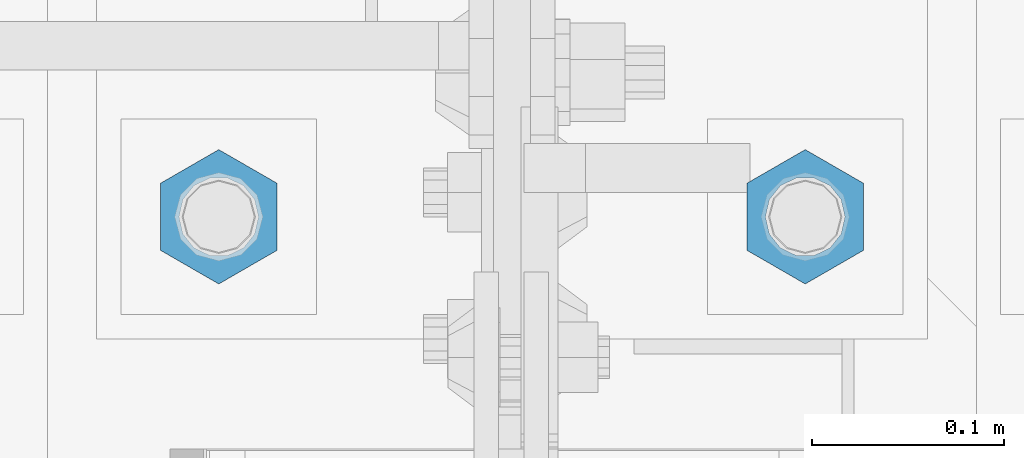
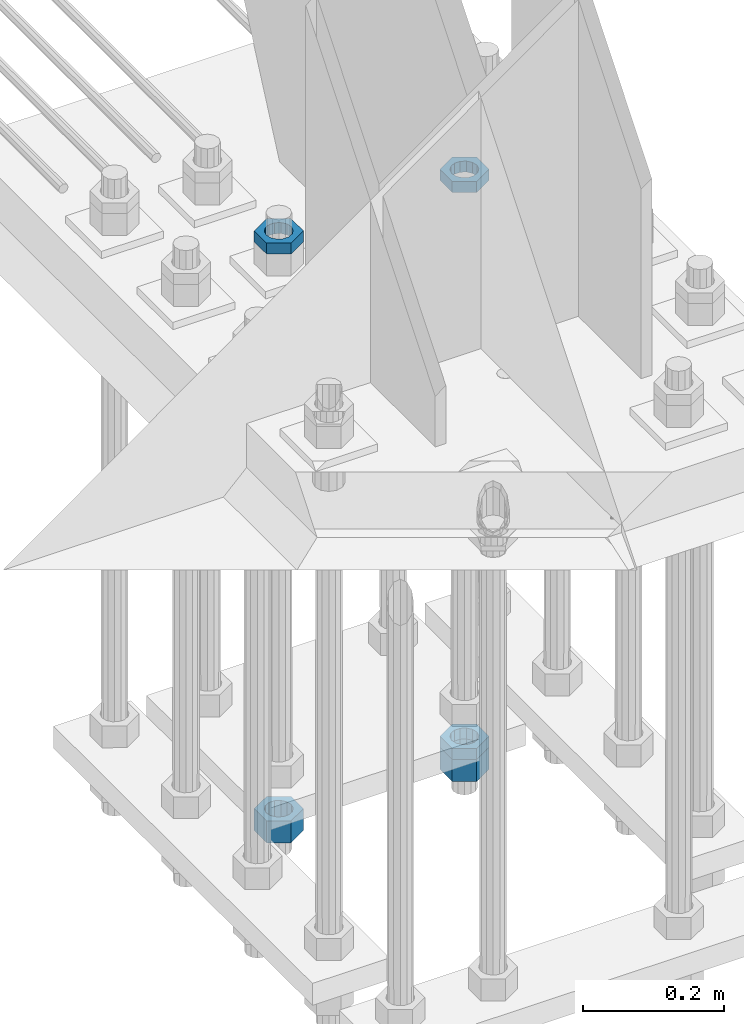
# One storey, part 2909 of 3843: 5 beams, 1 element without a shape of its own.
"""IFC2X3 building model written with IfcOpenShell, lengths in millimetres."""

from ifc_helpers import new_model, si_unit, frame, origin_with_axes, place, context, subcontext, project, spatial, faceted_brep, material, type_object, element, aggregate, save


model = new_model("IFC2X3")

# Units and contexts
model_context = context("Model", 3, precision=1e-05, world=origin_with_axes())
body_context = subcontext(model_context, "Body", "Model", "MODEL_VIEW")
ifc_project = project(units=[si_unit("LENGTHUNIT", "METRE", prefix="MILLI"), si_unit("AREAUNIT", "SQUARE_METRE"), si_unit("VOLUMEUNIT", "CUBIC_METRE"), si_unit("MASSUNIT", "GRAM", prefix="KILO"), si_unit("TIMEUNIT", "SECOND"), si_unit("PLANEANGLEUNIT", "RADIAN"), si_unit("SOLIDANGLEUNIT", "STERADIAN"), si_unit("THERMODYNAMICTEMPERATUREUNIT", "DEGREE_CELSIUS"), si_unit("LUMINOUSINTENSITYUNIT", "LUMEN")], contexts=[model_context])

# Site, building, storey
site_placement = place(None, origin_with_axes())
site = spatial("IfcSite", under=ifc_project, at=site_placement, CompositionType="ELEMENT")
building_placement = place(site_placement, origin_with_axes())
building = spatial("IfcBuilding", under=site, at=building_placement, Name="Undefined", CompositionType="ELEMENT")
storey_placement = place(building_placement, origin_with_axes())
storey = spatial("IfcBuildingStorey", under=building, at=storey_placement, Name="Undefined", CompositionType="ELEMENT", Elevation=0.0)

# Assembly, beams
assembly_placement = place(storey_placement, origin_with_axes())
assembly = element("IfcElementAssembly", 1, at=assembly_placement, inside=storey, Name="TEMPLATE", AssemblyPlace="NOTDEFINED", PredefinedType="RIGID_FRAME")
ifc_material = material(Name="STEEL/A572-50")
beam_type_1 = type_object("IfcBeamType", Name="1-1/2_HEAVY_HEX_NUT", PredefinedType="NOTDEFINED")
beam_1_placement = place(assembly_placement, frame((76860.4, 92519.5, 28746.4500015259), z_axis=(-1.0, 0.0, 0.0), x_axis=(0.0, 0.0, -1.0)))
beam_1 = element("IfcBeam", 2, at=beam_1_placement, type_object=beam_type_1, material=ifc_material, Name="NUT", ObjectType="1-1/2_HEAVY_HEX_NUT", context=body_context, shape_type="Brep", body=[
    faceted_brep([(0.0, -34.9199981689453, 0.0), (0.0, -17.4599990844727, -30.25), (38.0999999999985, -17.4599990844727, -30.25), (38.0999999999985, -34.9199981689453, 0.0), (0.0, 17.4599990844727, -30.25), (38.0999999999985, 17.4599990844727, -30.25), (0.0, 34.9199981689453, 0.0), (38.0999999999985, 34.9199981689453, 0.0), (0.0, 17.4599990844727, 30.25), (38.0999999999985, 17.4599990844727, 30.25), (0.0, -17.4599990844727, 30.25), (38.0999999999985, -17.4599990844727, 30.25), (0.0, 0.0, 20.6399993896484), (0.0, 8.9553601105581, 18.5959968835959), (38.0999999999985, 8.9553601105581, 18.5959968835959), (38.0999999999985, 0.0, 20.6399993896484), (0.0, 16.1370013209525, 12.8688291298167), (38.0999999999985, 16.1370013209525, 12.8688291298167), (0.0, 20.1225115123816, 4.59283194104501), (38.0999999999985, 20.1225115123816, 4.59283194104501), (0.0, 20.1225115123816, -4.59283194104501), (38.0999999999985, 20.1225115123816, -4.59283194104501), (0.0, 16.1370013209525, -12.8688291298167), (38.0999999999985, 16.1370013209525, -12.8688291298167), (0.0, 8.9553601105581, -18.5959968835959), (38.0999999999985, 8.9553601105581, -18.5959968835959), (0.0, 0.0, -20.6399993896484), (38.0999999999985, 0.0, -20.6399993896484), (0.0, -8.9553601105581, -18.5959968835959), (38.0999999999985, -8.9553601105581, -18.5959968835959), (0.0, -16.1370013209525, -12.8688291298167), (38.0999999999985, -16.1370013209525, -12.8688291298167), (0.0, -20.1225115123816, -4.59283194104501), (38.0999999999985, -20.1225115123816, -4.59283194104501), (0.0, -20.1225115123816, 4.59283194104501), (38.0999999999985, -20.1225115123816, 4.59283194104501), (0.0, -16.1370013209525, 12.8688291298167), (38.0999999999985, -16.1370013209525, 12.8688291298167), (0.0, -8.9553601105581, 18.5959968835959), (38.0999999999985, -8.9553601105581, 18.5959968835959)], [[[0, 1, 2, 3]], [[1, 4, 5, 2]], [[4, 6, 7, 5]], [[6, 8, 9, 7]], [[8, 10, 11, 9]], [[10, 0, 3, 11]], [[12, 13, 14, 15]], [[13, 16, 17, 14]], [[16, 18, 19, 17]], [[18, 20, 21, 19]], [[20, 22, 23, 21]], [[22, 24, 25, 23]], [[24, 26, 27, 25]], [[26, 28, 29, 27]], [[28, 30, 31, 29]], [[30, 32, 33, 31]], [[32, 34, 35, 33]], [[34, 36, 37, 35]], [[36, 38, 39, 37]], [[38, 12, 15, 39]], [[5, 7, 9, 11, 3, 2], [17, 19, 21, 23, 25, 27, 29, 31, 33, 35, 37, 39, 15, 14]], [[10, 8, 6, 4, 1, 0], [38, 36, 34, 32, 30, 28, 26, 24, 22, 20, 18, 16, 13, 12]]]),
])
beam_2_placement = place(assembly_placement, frame((77165.2, 92519.5, 28746.4500015259), z_axis=(-1.0, 0.0, 0.0), x_axis=(0.0, 0.0, -1.0)))
beam_2 = element("IfcBeam", 3, at=beam_2_placement, type_object=beam_type_1, material=ifc_material, Name="NUT", ObjectType="1-1/2_HEAVY_HEX_NUT", context=body_context, shape_type="Brep", body=[
    faceted_brep([(0.0, -34.9199981689453, 0.0), (0.0, -17.4599990844727, -30.25), (38.0999999999985, -17.4599990844727, -30.25), (38.0999999999985, -34.9199981689453, 0.0), (0.0, 17.4599990844727, -30.25), (38.0999999999985, 17.4599990844727, -30.25), (0.0, 34.9199981689453, 0.0), (38.0999999999985, 34.9199981689453, 0.0), (0.0, 17.4599990844727, 30.25), (38.0999999999985, 17.4599990844727, 30.25), (0.0, -17.4599990844727, 30.25), (38.0999999999985, -17.4599990844727, 30.25), (0.0, 0.0, 20.6399993896484), (0.0, 8.9553601105581, 18.5959968835959), (38.0999999999985, 8.9553601105581, 18.5959968835959), (38.0999999999985, 0.0, 20.6399993896484), (0.0, 16.1370013209525, 12.8688291298167), (38.0999999999985, 16.1370013209525, 12.8688291298167), (0.0, 20.1225115123816, 4.59283194104501), (38.0999999999985, 20.1225115123816, 4.59283194104501), (0.0, 20.1225115123816, -4.59283194104501), (38.0999999999985, 20.1225115123816, -4.59283194104501), (0.0, 16.1370013209525, -12.8688291298167), (38.0999999999985, 16.1370013209525, -12.8688291298167), (0.0, 8.9553601105581, -18.5959968835959), (38.0999999999985, 8.9553601105581, -18.5959968835959), (0.0, 0.0, -20.6399993896484), (38.0999999999985, 0.0, -20.6399993896484), (0.0, -8.9553601105581, -18.5959968835959), (38.0999999999985, -8.9553601105581, -18.5959968835959), (0.0, -16.1370013209525, -12.8688291298167), (38.0999999999985, -16.1370013209525, -12.8688291298167), (0.0, -20.1225115123816, -4.59283194104501), (38.0999999999985, -20.1225115123816, -4.59283194104501), (0.0, -20.1225115123816, 4.59283194104501), (38.0999999999985, -20.1225115123816, 4.59283194104501), (0.0, -16.1370013209525, 12.8688291298167), (38.0999999999985, -16.1370013209525, 12.8688291298167), (0.0, -8.9553601105581, 18.5959968835959), (38.0999999999985, -8.9553601105581, 18.5959968835959)], [[[0, 1, 2, 3]], [[1, 4, 5, 2]], [[4, 6, 7, 5]], [[6, 8, 9, 7]], [[8, 10, 11, 9]], [[10, 0, 3, 11]], [[12, 13, 14, 15]], [[13, 16, 17, 14]], [[16, 18, 19, 17]], [[18, 20, 21, 19]], [[20, 22, 23, 21]], [[22, 24, 25, 23]], [[24, 26, 27, 25]], [[26, 28, 29, 27]], [[28, 30, 31, 29]], [[30, 32, 33, 31]], [[32, 34, 35, 33]], [[34, 36, 37, 35]], [[36, 38, 39, 37]], [[38, 12, 15, 39]], [[5, 7, 9, 11, 3, 2], [17, 19, 21, 23, 25, 27, 29, 31, 33, 35, 37, 39, 15, 14]], [[10, 8, 6, 4, 1, 0], [38, 36, 34, 32, 30, 28, 26, 24, 22, 20, 18, 16, 13, 12]]]),
])
beam_type_2 = type_object("IfcBeamType", Name="1-1/2_HALF_NUT", PredefinedType="NOTDEFINED")
beam_3_placement = place(assembly_placement, frame((76860.4, 92519.5, 29749.75), z_axis=(-1.0, 0.0, 0.0), x_axis=(0.0, 0.0, -1.0)))
beam_3 = element("IfcBeam", 4, at=beam_3_placement, type_object=beam_type_2, material=ifc_material, Name="NUT", ObjectType="1-1/2_HALF_NUT", context=body_context, shape_type="Brep", body=[
    faceted_brep([(0.0, -34.9199981689453, 0.0), (0.0, -17.4599990844727, -30.25), (19.0500000000029, -17.4599990844727, -30.25), (19.0500000000029, -34.9199981689453, 0.0), (0.0, 17.4599990844727, -30.25), (19.0500000000029, 17.4599990844727, -30.25), (0.0, 34.9199981689453, 0.0), (19.0500000000029, 34.9199981689453, 0.0), (0.0, 17.4599990844727, 30.25), (19.0500000000029, 17.4599990844727, 30.25), (0.0, -17.4599990844727, 30.25), (19.0500000000029, -17.4599990844727, 30.25), (0.0, 0.0, 20.6399993896484), (0.0, 8.9553601105581, 18.5959968835959), (19.0500000000029, 8.95536011056538, 18.5959968835959), (19.0500000000029, 0.0, 20.6399993896484), (0.0, 16.1370013209525, 12.8688291298167), (19.0500000000029, 16.1370013209489, 12.8688291298167), (0.0, 20.1225115123816, 4.59283194104501), (19.0500000000029, 20.1225115123852, 4.59283194104501), (0.0, 20.1225115123816, -4.59283194104501), (19.0500000000029, 20.1225115123852, -4.59283194104501), (0.0, 16.1370013209525, -12.8688291298167), (19.0500000000029, 16.1370013209489, -12.8688291298167), (0.0, 8.9553601105581, -18.5959968835959), (19.0500000000029, 8.95536011056538, -18.5959968835959), (0.0, 0.0, -20.6399993896484), (19.0500000000029, 0.0, -20.6399993896484), (0.0, -8.9553601105581, -18.5959968835959), (19.0500000000029, -8.95536011056538, -18.5959968835959), (0.0, -16.1370013209525, -12.8688291298167), (19.0500000000029, -16.1370013209489, -12.8688291298167), (0.0, -20.1225115123816, -4.59283194104501), (19.0500000000029, -20.1225115123852, -4.59283194104501), (0.0, -20.1225115123816, 4.59283194104501), (19.0500000000029, -20.1225115123852, 4.59283194104501), (0.0, -16.1370013209525, 12.8688291298167), (19.0500000000029, -16.1370013209489, 12.8688291298167), (0.0, -8.9553601105581, 18.5959968835959), (19.0500000000029, -8.95536011056538, 18.5959968835959)], [[[0, 1, 2, 3]], [[1, 4, 5, 2]], [[4, 6, 7, 5]], [[6, 8, 9, 7]], [[8, 10, 11, 9]], [[10, 0, 3, 11]], [[12, 13, 14, 15]], [[13, 16, 17, 14]], [[16, 18, 19, 17]], [[18, 20, 21, 19]], [[20, 22, 23, 21]], [[22, 24, 25, 23]], [[24, 26, 27, 25]], [[26, 28, 29, 27]], [[28, 30, 31, 29]], [[30, 32, 33, 31]], [[32, 34, 35, 33]], [[34, 36, 37, 35]], [[36, 38, 39, 37]], [[38, 12, 15, 39]], [[5, 7, 9, 11, 3, 2], [17, 19, 21, 23, 25, 27, 29, 31, 33, 35, 37, 39, 15, 14]], [[10, 8, 6, 4, 1, 0], [38, 36, 34, 32, 30, 28, 26, 24, 22, 20, 18, 16, 13, 12]]]),
])
beam_4_placement = place(assembly_placement, frame((77165.2, 92519.5, 28765.5000015259), z_axis=(-1.0, 0.0, 0.0), x_axis=(0.0, 0.0, -1.0)))
beam_4 = element("IfcBeam", 5, at=beam_4_placement, type_object=beam_type_2, material=ifc_material, Name="NUT", ObjectType="1-1/2_HALF_NUT", context=body_context, shape_type="Brep", body=[
    faceted_brep([(0.0, -34.9199981689453, 0.0), (0.0, -17.4599990844727, -30.25), (19.0500000000029, -17.4599990844727, -30.25), (19.0500000000029, -34.9199981689453, 0.0), (0.0, 17.4599990844727, -30.25), (19.0500000000029, 17.4599990844727, -30.25), (0.0, 34.9199981689453, 0.0), (19.0500000000029, 34.9199981689453, 0.0), (0.0, 17.4599990844727, 30.25), (19.0500000000029, 17.4599990844727, 30.25), (0.0, -17.4599990844727, 30.25), (19.0500000000029, -17.4599990844727, 30.25), (0.0, 0.0, 20.6399993896484), (0.0, 8.9553601105581, 18.5959968835959), (19.0500000000029, 8.95536011056538, 18.5959968835959), (19.0500000000029, 0.0, 20.6399993896484), (0.0, 16.1370013209525, 12.8688291298167), (19.0500000000029, 16.1370013209489, 12.8688291298167), (0.0, 20.1225115123816, 4.59283194104501), (19.0500000000029, 20.1225115123852, 4.59283194104501), (0.0, 20.1225115123816, -4.59283194104501), (19.0500000000029, 20.1225115123852, -4.59283194104501), (0.0, 16.1370013209525, -12.8688291298167), (19.0500000000029, 16.1370013209489, -12.8688291298167), (0.0, 8.9553601105581, -18.5959968835959), (19.0500000000029, 8.95536011056538, -18.5959968835959), (0.0, 0.0, -20.6399993896484), (19.0500000000029, 0.0, -20.6399993896484), (0.0, -8.9553601105581, -18.5959968835959), (19.0500000000029, -8.95536011056538, -18.5959968835959), (0.0, -16.1370013209525, -12.8688291298167), (19.0500000000029, -16.1370013209489, -12.8688291298167), (0.0, -20.1225115123816, -4.59283194104501), (19.0500000000029, -20.1225115123852, -4.59283194104501), (0.0, -20.1225115123816, 4.59283194104501), (19.0500000000029, -20.1225115123852, 4.59283194104501), (0.0, -16.1370013209525, 12.8688291298167), (19.0500000000029, -16.1370013209489, 12.8688291298167), (0.0, -8.9553601105581, 18.5959968835959), (19.0500000000029, -8.95536011056538, 18.5959968835959)], [[[0, 1, 2, 3]], [[1, 4, 5, 2]], [[4, 6, 7, 5]], [[6, 8, 9, 7]], [[8, 10, 11, 9]], [[10, 0, 3, 11]], [[12, 13, 14, 15]], [[13, 16, 17, 14]], [[16, 18, 19, 17]], [[18, 20, 21, 19]], [[20, 22, 23, 21]], [[22, 24, 25, 23]], [[24, 26, 27, 25]], [[26, 28, 29, 27]], [[28, 30, 31, 29]], [[30, 32, 33, 31]], [[32, 34, 35, 33]], [[34, 36, 37, 35]], [[36, 38, 39, 37]], [[38, 12, 15, 39]], [[5, 7, 9, 11, 3, 2], [17, 19, 21, 23, 25, 27, 29, 31, 33, 35, 37, 39, 15, 14]], [[10, 8, 6, 4, 1, 0], [38, 36, 34, 32, 30, 28, 26, 24, 22, 20, 18, 16, 13, 12]]]),
])
beam_5_placement = place(assembly_placement, frame((77165.2, 92519.5, 29749.75), z_axis=(-1.0, 0.0, 0.0), x_axis=(0.0, 0.0, -1.0)))
beam_5 = element("IfcBeam", 6, at=beam_5_placement, type_object=beam_type_2, material=ifc_material, Name="NUT", ObjectType="1-1/2_HALF_NUT", context=body_context, shape_type="Brep", body=[
    faceted_brep([(0.0, -34.9199981689453, 0.0), (0.0, -17.4599990844727, -30.25), (19.0500000000029, -17.4599990844727, -30.25), (19.0500000000029, -34.9199981689453, 0.0), (0.0, 17.4599990844727, -30.25), (19.0500000000029, 17.4599990844727, -30.25), (0.0, 34.9199981689453, 0.0), (19.0500000000029, 34.9199981689453, 0.0), (0.0, 17.4599990844727, 30.25), (19.0500000000029, 17.4599990844727, 30.25), (0.0, -17.4599990844727, 30.25), (19.0500000000029, -17.4599990844727, 30.25), (0.0, 0.0, 20.6399993896484), (0.0, 8.9553601105581, 18.5959968835959), (19.0500000000029, 8.95536011056538, 18.5959968835959), (19.0500000000029, 0.0, 20.6399993896484), (0.0, 16.1370013209525, 12.8688291298167), (19.0500000000029, 16.1370013209489, 12.8688291298167), (0.0, 20.1225115123816, 4.59283194104501), (19.0500000000029, 20.1225115123852, 4.59283194104501), (0.0, 20.1225115123816, -4.59283194104501), (19.0500000000029, 20.1225115123852, -4.59283194104501), (0.0, 16.1370013209525, -12.8688291298167), (19.0500000000029, 16.1370013209489, -12.8688291298167), (0.0, 8.9553601105581, -18.5959968835959), (19.0500000000029, 8.95536011056538, -18.5959968835959), (0.0, 0.0, -20.6399993896484), (19.0500000000029, 0.0, -20.6399993896484), (0.0, -8.9553601105581, -18.5959968835959), (19.0500000000029, -8.95536011056538, -18.5959968835959), (0.0, -16.1370013209525, -12.8688291298167), (19.0500000000029, -16.1370013209489, -12.8688291298167), (0.0, -20.1225115123816, -4.59283194104501), (19.0500000000029, -20.1225115123852, -4.59283194104501), (0.0, -20.1225115123816, 4.59283194104501), (19.0500000000029, -20.1225115123852, 4.59283194104501), (0.0, -16.1370013209525, 12.8688291298167), (19.0500000000029, -16.1370013209489, 12.8688291298167), (0.0, -8.9553601105581, 18.5959968835959), (19.0500000000029, -8.95536011056538, 18.5959968835959)], [[[0, 1, 2, 3]], [[1, 4, 5, 2]], [[4, 6, 7, 5]], [[6, 8, 9, 7]], [[8, 10, 11, 9]], [[10, 0, 3, 11]], [[12, 13, 14, 15]], [[13, 16, 17, 14]], [[16, 18, 19, 17]], [[18, 20, 21, 19]], [[20, 22, 23, 21]], [[22, 24, 25, 23]], [[24, 26, 27, 25]], [[26, 28, 29, 27]], [[28, 30, 31, 29]], [[30, 32, 33, 31]], [[32, 34, 35, 33]], [[34, 36, 37, 35]], [[36, 38, 39, 37]], [[38, 12, 15, 39]], [[5, 7, 9, 11, 3, 2], [17, 19, 21, 23, 25, 27, 29, 31, 33, 35, 37, 39, 15, 14]], [[10, 8, 6, 4, 1, 0], [38, 36, 34, 32, 30, 28, 26, 24, 22, 20, 18, 16, 13, 12]]]),
])
aggregate(assembly, [beam_1, beam_3, beam_4, beam_2, beam_5])

save(model, "model.ifc")
